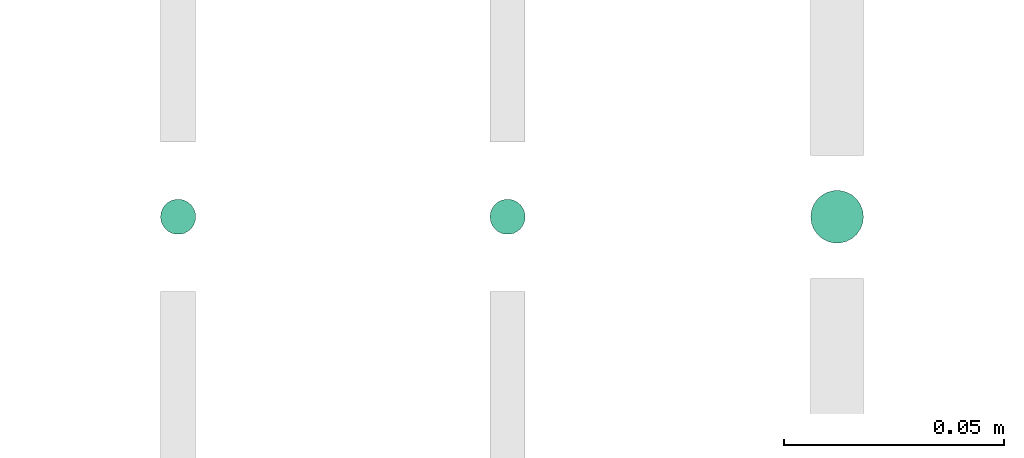
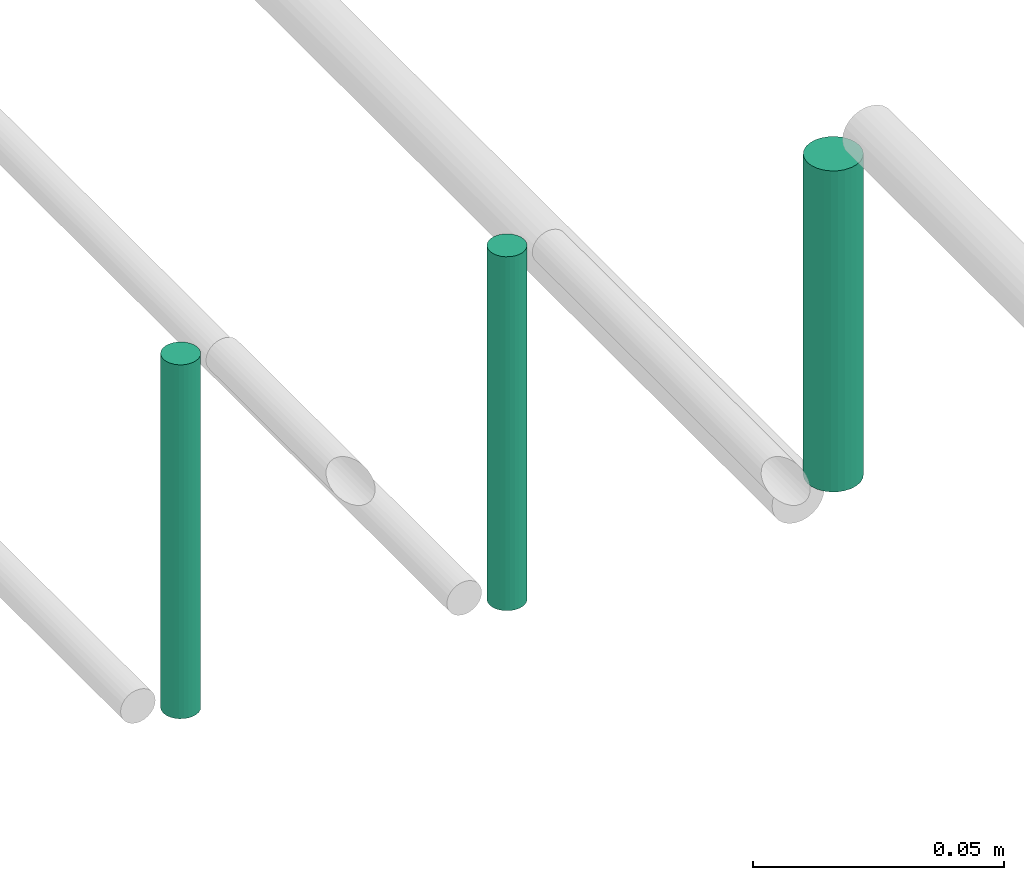
# One storey, part 304 of 331: 3 flow segments.
"""IFC2X3 building model written with IfcOpenShell, lengths in millimetres."""

import ifcopenshell
import ifcopenshell.guid

model = None  # the IFC model being written
_history = None  # IfcOwnerHistory: only IFC2X3 demands one
_inside = {}  # id of a spatial element -> (the spatial element, [elements in it])
_under = {}  # id of a project, library or spatial element -> (it, [spatial elements below it])
_declared = {}  # id of a project -> (the project, [libraries it declares])
_typed = {}  # id of a type object -> (the type object, [elements of that type])
_made_of = {}  # id of a material, layer set ... -> (it, [elements and type objects made of it])


def new_model(schema):
    """Start an empty IFC model of exactly this schema.

    Asked for "IFC4X3", IfcOpenShell would pick the latest addendum, in which some entities
    have other attributes; the version numbers below select the first issue.
    IFC2X3 requires an IfcOwnerHistory on every rooted entity: one is made here for all.
    """
    global model, _history
    if schema == "IFC4X3":
        model = ifcopenshell.file(schema_version=(4, 3, 0, 0))
    else:
        model = ifcopenshell.file(schema=schema)
    _inside.clear()
    _under.clear()
    _declared.clear()
    _typed.clear()
    _made_of.clear()
    _history = None
    if model.schema == "IFC2X3":
        org = make("IfcOrganization", Name="unknown")
        user = make(
            "IfcPersonAndOrganization",
            ThePerson=make("IfcPerson", FamilyName="unknown"),
            TheOrganization=org,
        )
        app = make(
            "IfcApplication",
            ApplicationDeveloper=org,
            Version="unknown",
            ApplicationFullName="unknown",
            ApplicationIdentifier="unknown",
        )
        _history = make(
            "IfcOwnerHistory",
            OwningUser=user,
            OwningApplication=app,
            ChangeAction="ADDED",
            CreationDate=0,
        )
    return model


def make(cls, **values):
    """One entity of the class cls with the attributes given. An attribute that is None is left unset."""
    return model.create_entity(
        cls, **{name: value for name, value in values.items() if value is not None}
    )


def entity(cls, *values):
    """Any entity or typed value of the class cls, its attributes in the order of the schema. None: left unset."""
    e = model.create_entity(cls)
    for i, value in enumerate(values):
        if value is not None:
            e[i] = value
    return e


def rooted(cls, **values):
    """An entity with a GlobalId (a new one), such as an element, a storey or a relation."""
    return make(cls, GlobalId=ifcopenshell.guid.new(), OwnerHistory=_history, **values)


def si_unit(unit_type, name, prefix=None):
    """IfcSIUnit, for example si_unit("LENGTHUNIT", "METRE", prefix="MILLI")."""
    return make("IfcSIUnit", UnitType=unit_type, Prefix=prefix, Name=name)


def converted_unit(unit_type, name, factor, base, dimensions=None, offset=None):
    """IfcConversionBasedUnit, such as the inch: factor (a typed value) times the base unit."""
    return make(
        "IfcConversionBasedUnit"
        if offset is None
        else "IfcConversionBasedUnitWithOffset",
        ConversionOffset=offset,
        Dimensions=None
        if dimensions is None
        else entity("IfcDimensionalExponents", *dimensions),
        UnitType=unit_type,
        Name=name,
        ConversionFactor=make(
            "IfcMeasureWithUnit", ValueComponent=factor, UnitComponent=base
        ),
    )


def derived_unit(unit_type, elements):
    """IfcDerivedUnit: a product of units, each with its exponent."""
    return make(
        "IfcDerivedUnit",
        Elements=[
            make("IfcDerivedUnitElement", Unit=unit, Exponent=power)
            for unit, power in elements
        ],
        UnitType=unit_type,
    )


def assignment(units):
    """IfcUnitAssignment: the units of a project."""
    return None if units is None else make("IfcUnitAssignment", Units=units)


def point(xyz):
    """IfcCartesianPoint."""
    return None if xyz is None else make("IfcCartesianPoint", Coordinates=xyz)


def direction(xyz):
    """IfcDirection."""
    return None if xyz is None else make("IfcDirection", DirectionRatios=xyz)


def frame(location, z_axis=None, x_axis=None):
    """IfcAxis2Placement3D, a coordinate frame: its origin and axes. An axis left out is left unset."""
    return make(
        "IfcAxis2Placement3D",
        Location=point(location),
        Axis=direction(z_axis),
        RefDirection=direction(x_axis),
    )


def frame_2d(location, x_axis=None):
    """IfcAxis2Placement2D, a coordinate frame in the plane: its origin and x axis."""
    return make(
        "IfcAxis2Placement2D", Location=point(location), RefDirection=direction(x_axis)
    )


def origin():
    """The frame at (0, 0, 0) with its axes left unset."""
    return frame((0.0, 0.0, 0.0))


def origin_2d_with_axis():
    """The frame at (0, 0) in the plane with the x axis (1, 0) written out."""
    return frame_2d((0.0, 0.0), x_axis=(1.0, 0.0))


def place(relative_to, where):
    """IfcLocalPlacement: puts the frame where relative to a parent placement (None: the world)."""
    return make(
        "IfcLocalPlacement", PlacementRelTo=relative_to, RelativePlacement=where
    )


def context(
    kind, dimensions, precision=None, world=None, true_north=None, identifier=None
):
    """IfcGeometricRepresentationContext, for example the 3D "Model" context."""
    return make(
        "IfcGeometricRepresentationContext",
        ContextIdentifier=identifier,
        ContextType=kind,
        CoordinateSpaceDimension=dimensions,
        Precision=precision,
        WorldCoordinateSystem=world,
        TrueNorth=true_north,
    )


def subcontext(parent, identifier, kind, view, scale=None):
    """IfcGeometricRepresentationSubContext, for example "Body" below "Model"."""
    return make(
        "IfcGeometricRepresentationSubContext",
        ContextIdentifier=identifier,
        ContextType=kind,
        ParentContext=parent,
        TargetScale=scale,
        TargetView=view,
    )


def project(units=None, contexts=None):
    """IfcProject with its units and contexts."""
    return rooted(
        "IfcProject",
        Name="project",
        RepresentationContexts=contexts,
        UnitsInContext=assignment(units),
    )


def spatial(cls, under=None, at=None, **own):
    """A site, building, storey or space (cls), placed at a placement, below another one or the project."""
    s = rooted(cls, ObjectPlacement=at, **own)
    if under is not None:
        _under.setdefault(under.id(), (under, []))[1].append(s)
    return s


def profile(cls, at=None, kind="AREA", **sizes):
    """A parametric profile (cls). Its sizes go by their IFC names, for example OverallWidth=200.0."""
    return make(cls, ProfileType=kind, Position=at, **sizes)


def circle(**sizes):
    """IfcCircleProfileDef."""
    return profile("IfcCircleProfileDef", **sizes)


def extrude(swept, where, along, depth):
    """IfcExtrudedAreaSolid: the profile swept, set in the frame where, extruded along a direction by depth."""
    return make(
        "IfcExtrudedAreaSolid",
        SweptArea=swept,
        Position=where,
        ExtrudedDirection=direction(along),
        Depth=depth,
    )


def shape(context_of_items, identifier, shape_type, items):
    """IfcShapeRepresentation: the items that make up one representation, for example the "Body"."""
    return make(
        "IfcShapeRepresentation",
        ContextOfItems=context_of_items,
        RepresentationIdentifier=identifier,
        RepresentationType=shape_type,
        Items=items,
    )


def made_of(thing, what):
    """Note that an element or type object is made of a material, layer set ...; save() writes the relation."""
    if what is not None:
        _made_of.setdefault(what.id(), (what, []))[1].append(thing)
    return thing


def type_object(cls, material=None, **own):
    """A type object (cls), such as IfcWallType, which elements share."""
    return made_of(rooted(cls, **own), material)


def element(
    cls,
    number,
    at=None,
    inside=None,
    cuts=None,
    type_object=None,
    material=None,
    context=None,
    identifier="Body",
    shape_type=None,
    held_by="IfcProductDefinitionShape",
    body=None,
    shapes=None,
    **own,
):
    """One element of the class cls, such as IfcWall. Its Tag is "e" and its number.

    at: its placement. inside: the storey or other place that contains it. cuts: it is an
    opening in that element (IfcRelVoidsElement). A single representation is given by context,
    identifier, shape_type and body (its items); several are given by shapes. held_by: the class
    of the entity that holds the representations. save() writes the other relations.
    """
    e = rooted(cls, Tag="e%d" % number, ObjectPlacement=at, **own)
    if body is not None:
        shapes = [shape(context, identifier, shape_type, body)]
    if shapes is not None:
        e.Representation = make(held_by, Representations=shapes)
    if inside is not None:
        _inside.setdefault(inside.id(), (inside, []))[1].append(e)
    if cuts is not None:
        rooted(
            "IfcRelVoidsElement", RelatingBuildingElement=cuts, RelatedOpeningElement=e
        )
    if type_object is not None:
        _typed.setdefault(type_object.id(), (type_object, []))[1].append(e)
    return made_of(e, material)


def aggregate(whole, parts):
    """IfcRelAggregates: a whole, such as a stair, and the parts it consists of."""
    return rooted("IfcRelAggregates", RelatingObject=whole, RelatedObjects=parts)


def save(model, path):
    """Write the relations noted so far, then the file.

    IfcRelAggregates (storeys below a building ...), IfcRelContainedInSpatialStructure (elements
    in a storey), IfcRelDefinesByType, IfcRelAssociatesMaterial and IfcRelDeclares: one each for
    every whole, place, type object, material and project.
    """
    for whole, parts in _under.values():
        aggregate(whole, parts)
    for where, things in _inside.values():
        rooted(
            "IfcRelContainedInSpatialStructure",
            RelatedElements=things,
            RelatingStructure=where,
        )
    for kind, things in _typed.values():
        rooted("IfcRelDefinesByType", RelatedObjects=things, RelatingType=kind)
    for what, things in _made_of.values():
        rooted("IfcRelAssociatesMaterial", RelatedObjects=things, RelatingMaterial=what)
    for by, libraries in _declared.values():
        rooted("IfcRelDeclares", RelatingContext=by, RelatedDefinitions=libraries)
    model.write(path)


model = new_model("IFC2X3")

# Units and contexts
model_context = context("Model", 3, precision=0.01, world=origin(), true_north=direction((6.12303176911189e-17, 1.0)))
body_context = subcontext(model_context, "Body", "Model", "MODEL_VIEW")
ifc_project = project(units=[si_unit("LENGTHUNIT", "METRE", prefix="MILLI"), si_unit("AREAUNIT", "SQUARE_METRE"), si_unit("VOLUMEUNIT", "CUBIC_METRE"), converted_unit("PLANEANGLEUNIT", "DEGREE", entity("IfcRatioMeasure", 0.0174532925199433), si_unit("PLANEANGLEUNIT", "RADIAN"), dimensions=[0, 0, 0, 0, 0, 0, 0]), si_unit("MASSUNIT", "GRAM", prefix="KILO"), derived_unit("MASSDENSITYUNIT", [(si_unit("MASSUNIT", "GRAM", prefix="KILO"), 1), (si_unit("LENGTHUNIT", "METRE"), -3)]), derived_unit("MOMENTOFINERTIAUNIT", [(si_unit("LENGTHUNIT", "METRE"), 4)]), si_unit("TIMEUNIT", "SECOND"), si_unit("FREQUENCYUNIT", "HERTZ"), si_unit("THERMODYNAMICTEMPERATUREUNIT", "DEGREE_CELSIUS"), derived_unit("THERMALTRANSMITTANCEUNIT", [(si_unit("MASSUNIT", "GRAM", prefix="KILO"), 1), (si_unit("THERMODYNAMICTEMPERATUREUNIT", "KELVIN"), -1), (si_unit("TIMEUNIT", "SECOND"), -3)]), derived_unit("VOLUMETRICFLOWRATEUNIT", [(si_unit("LENGTHUNIT", "METRE"), 3), (si_unit("TIMEUNIT", "SECOND"), -1)]), derived_unit("MASSFLOWRATEUNIT", [(si_unit("MASSUNIT", "GRAM", prefix="KILO"), 1), (si_unit("TIMEUNIT", "SECOND"), -1)]), derived_unit("ROTATIONALFREQUENCYUNIT", [(si_unit("TIMEUNIT", "SECOND"), -1)]), si_unit("ELECTRICCURRENTUNIT", "AMPERE"), si_unit("ELECTRICVOLTAGEUNIT", "VOLT"), si_unit("POWERUNIT", "WATT"), si_unit("FORCEUNIT", "NEWTON", prefix="KILO"), si_unit("ILLUMINANCEUNIT", "LUX"), si_unit("LUMINOUSFLUXUNIT", "LUMEN"), si_unit("LUMINOUSINTENSITYUNIT", "CANDELA"), derived_unit("USERDEFINED", [(si_unit("MASSUNIT", "GRAM", prefix="KILO"), -1), (si_unit("LENGTHUNIT", "METRE"), -2), (si_unit("TIMEUNIT", "SECOND"), 3), (si_unit("LUMINOUSFLUXUNIT", "LUMEN"), 1)]), derived_unit("LINEARVELOCITYUNIT", [(si_unit("LENGTHUNIT", "METRE"), 1), (si_unit("TIMEUNIT", "SECOND"), -1)]), si_unit("PRESSUREUNIT", "PASCAL"), derived_unit("USERDEFINED", [(si_unit("LENGTHUNIT", "METRE"), -2), (si_unit("MASSUNIT", "GRAM", prefix="KILO"), 1), (si_unit("TIMEUNIT", "SECOND"), -2)]), derived_unit("LINEARFORCEUNIT", [(si_unit("MASSUNIT", "GRAM", prefix="KILO"), 1), (si_unit("LENGTHUNIT", "METRE"), 1), (si_unit("TIMEUNIT", "SECOND"), -2), (si_unit("LENGTHUNIT", "METRE"), -1)]), derived_unit("PLANARFORCEUNIT", [(si_unit("MASSUNIT", "GRAM", prefix="KILO"), 1), (si_unit("LENGTHUNIT", "METRE"), 1), (si_unit("TIMEUNIT", "SECOND"), -2), (si_unit("LENGTHUNIT", "METRE"), -2)])], contexts=[model_context])

# Site, building, storey
site_placement = place(None, frame((0.0, -0.00077364408347762, 0.0)))
site = spatial("IfcSite", under=ifc_project, at=site_placement, CompositionType="ELEMENT")
building_placement = place(site_placement, origin())
building = spatial("IfcBuilding", under=site, at=building_placement, CompositionType="ELEMENT")
storey_placement = place(building_placement, origin())
storey = spatial("IfcBuildingStorey", under=building, at=storey_placement, CompositionType="ELEMENT", Elevation=0.0)

# Flow segments
pipe_segment_type = type_object("IfcPipeSegmentType", PredefinedType="NOTDEFINED")
flow_segment_placement = place(building_placement, frame((65227.5100168243, 3904.9045804717, 7264.0)))
element("IfcFlowSegment", 1, at=flow_segment_placement, inside=storey, type_object=pipe_segment_type, context=body_context, shape_type="SweptSolid", body=[
    extrude(circle(Radius=6.0, at=origin_2d_with_axis()), frame((7.59527223591454, 7.59527223591616, 0.0), z_axis=(0.0, 0.0, 1.0), x_axis=(-1.0, 0.0, 0.0)), (0.0, 0.0, 1.0), 78.0000000000007),
])
for number, where in (
    (2, (65154.5100168243, 3906.9045804717, 7260.0)),
    (3, (65079.5100168243, 3906.9045804717, 7260.0)),
):
    element("IfcFlowSegment", number, at=place(storey_placement, frame(where)), inside=storey, type_object=pipe_segment_type, context=body_context, shape_type="SweptSolid", body=[
        extrude(circle(Radius=4.0, at=origin_2d_with_axis()), frame((5.59527223591499, 5.59527223591607, 0.0), z_axis=(0.0, 0.0, 1.0), x_axis=(-1.0, 0.0, 0.0)), (0.0, 0.0, 1.0), 86.000000000001),
    ])

save(model, "model.ifc")
